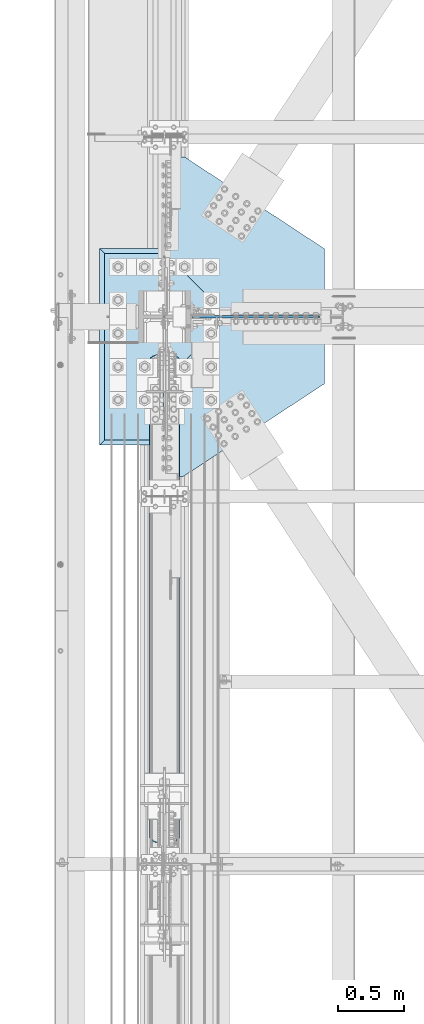
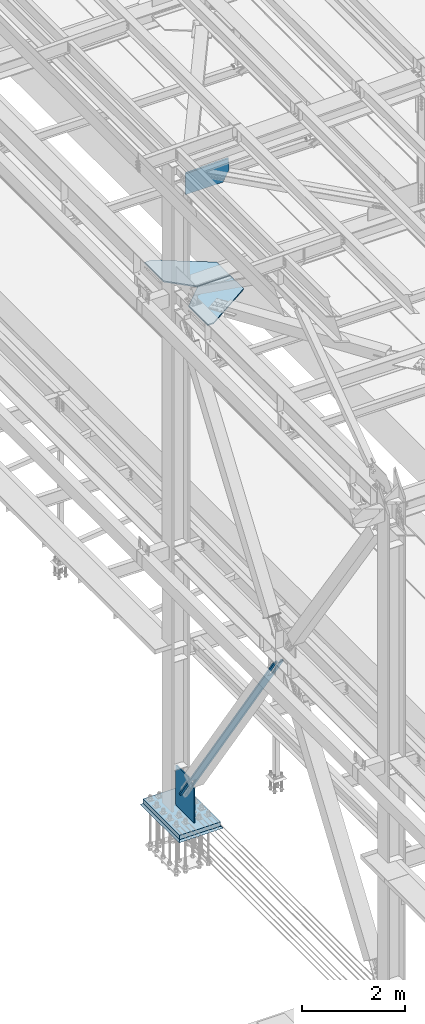
# One storey, part 2978 of 3843: 7 plates, 6 elements without a shape of their own.
"""IFC2X3 building model written with IfcOpenShell, lengths in millimetres."""

from ifc_helpers import new_model, si_unit, frame, origin_with_axes, place, context, subcontext, project, spatial, faceted_brep, material, type_object, element, aggregate, save


model = new_model("IFC2X3")

# Units and contexts
model_context = context("Model", 3, precision=1e-05, world=origin_with_axes())
body_context = subcontext(model_context, "Body", "Model", "MODEL_VIEW")
ifc_project = project(units=[si_unit("LENGTHUNIT", "METRE", prefix="MILLI"), si_unit("AREAUNIT", "SQUARE_METRE"), si_unit("VOLUMEUNIT", "CUBIC_METRE"), si_unit("MASSUNIT", "GRAM", prefix="KILO"), si_unit("TIMEUNIT", "SECOND"), si_unit("PLANEANGLEUNIT", "RADIAN"), si_unit("SOLIDANGLEUNIT", "STERADIAN"), si_unit("THERMODYNAMICTEMPERATUREUNIT", "DEGREE_CELSIUS"), si_unit("LUMINOUSINTENSITYUNIT", "LUMEN")], contexts=[model_context])

# Site, building, storey
site_placement = place(None, origin_with_axes())
site = spatial("IfcSite", under=ifc_project, at=site_placement, CompositionType="ELEMENT")
building_placement = place(site_placement, origin_with_axes())
building = spatial("IfcBuilding", under=site, at=building_placement, Name="Undefined", CompositionType="ELEMENT")
storey_placement = place(building_placement, origin_with_axes())
storey = spatial("IfcBuildingStorey", under=building, at=storey_placement, Name="Undefined", CompositionType="ELEMENT", Elevation=0.0)

# Assembly, plate
assembly_1_placement = place(storey_placement, origin_with_axes())
assembly_1 = element("IfcElementAssembly", 1, at=assembly_1_placement, inside=storey, Name="PLATE", AssemblyPlace="NOTDEFINED", PredefinedType="RIGID_FRAME")
ifc_material_1 = material(Name="STEEL/A572-50")
plate_type_1 = type_object("IfcPlateType", PredefinedType="NOTDEFINED")
plate_1_placement = place(assembly_1_placement, frame((36583.1437500017, 58432.7, 42232.2630004885), z_axis=(1.0, 0.0, 0.0), x_axis=(0.0, -1.0, 0.0)))
plate_1 = element("IfcPlate", 2, at=plate_1_placement, type_object=plate_type_1, material=ifc_material_1, Name="PLATE", context=body_context, shape_type="Brep", body=[
    faceted_brep([(0.0, -14.2874999999985, 0.0), (-475.456249998751, -14.2874999999985, 475.456249999283), (-475.456249998751, 14.2874999999985, 475.456249999283), (0.0, 14.2874999999985, 0.0), (-475.456249998751, -14.2874999999985, 1212.05624999934), (-475.456249998751, 14.2874999999985, 1212.05624999934), (28.9127655419579, -14.2874999999985, 1212.05624999934), (28.9127655419579, 14.2874999999985, 1212.05624999934), (736.600000000006, -14.2874999999985, 134.143749999275), (736.600000000006, 14.2874999999985, 134.143749999275), (736.599999940488, -14.2874999999985, 0.0), (736.599999940488, 14.2874999999985, 0.0)], [[[0, 1, 2, 3]], [[1, 4, 5, 2]], [[4, 6, 7, 5]], [[6, 8, 9, 7]], [[8, 10, 11, 9]], [[10, 0, 3, 11]], [[5, 7, 9, 11, 3, 2]], [[10, 8, 6, 4, 1, 0]]]),
])
aggregate(assembly_1, [plate_1])

assembly_2_placement = place(storey_placement, origin_with_axes())
assembly_2 = element("IfcElementAssembly", 3, at=assembly_2_placement, inside=storey, Name="PLATE", AssemblyPlace="NOTDEFINED", PredefinedType="RIGID_FRAME")
plate_2_placement = place(assembly_2_placement, frame((37058.6, 58922.4437500015, 42232.2630004888), z_axis=(0.0, 1.0, 0.0), x_axis=(1.0, 0.0, 0.0)))
plate_2 = element("IfcPlate", 4, at=plate_2_placement, type_object=plate_type_1, material=ifc_material_1, Name="PLATE", context=body_context, shape_type="Brep", body=[
    faceted_brep([(0.0, -14.2874999999985, 0.0), (-476.249999993554, -14.2874999999985, 475.456250073548), (-476.249999993554, 14.2874999999985, 475.456250073548), (0.0, 14.2874999999985, 0.0), (-476.249999993568, -14.2874999999985, 1212.05625003844), (-476.249999993568, 14.2874999999985, 1212.05625003844), (-327.025000000001, -14.2874999999985, 1212.05624999852), (-327.025000000001, 14.2874999999985, 1212.05624999852), (736.599999997103, -14.2874999999985, 513.749258709016), (736.599999997103, 14.2874999999985, 513.749258709016), (736.599999940488, -14.2874999999985, 0.0), (736.599999940488, 14.2874999999985, 0.0)], [[[0, 1, 2, 3]], [[1, 4, 5, 2]], [[4, 6, 7, 5]], [[6, 8, 9, 7]], [[8, 10, 11, 9]], [[10, 0, 3, 11]], [[5, 7, 9, 11, 3, 2]], [[10, 8, 6, 4, 1, 0]]]),
])
aggregate(assembly_2, [plate_2])

assembly_3_placement = place(storey_placement, origin_with_axes())
assembly_3 = element("IfcElementAssembly", 5, at=assembly_3_placement, inside=storey, Name="BEAM", AssemblyPlace="NOTDEFINED", PredefinedType="RIGID_FRAME")
plate_type_2 = type_object("IfcPlateType", PredefinedType="NOTDEFINED")
plate_3_placement = place(assembly_3_placement, frame((36788.7249999795, 58915.3, 45030.0717313356), z_axis=(1.0, 0.0, 0.0), x_axis=(0.0, 0.0, -1.0)))
plate_3 = element("IfcPlate", 6, at=plate_3_placement, type_object=plate_type_2, material=ifc_material_1, Name="PLATE", context=body_context, shape_type="Brep", body=[
    faceted_brep([(-4.08604394921713, -9.52500000000146, 962.266908610043), (-23.1289214823482, 9.52500000000146, 961.746057199307), (3.17628316901391, 9.52500000000146, 0.0), (22.2334067734992, -9.52500000000146, 0.0), (270.121220165929, -9.52500000000146, 969.766890695173), (270.121220165929, 9.52500000000146, 969.766890695173), (516.322274450198, -9.52500000000146, 837.670706379751), (516.322274450198, 9.52500000000146, 837.670706379751), (516.322274450198, -9.52500000000146, 0.0), (516.322274450198, 9.52500000000146, 0.0)], [[[0, 1, 2, 3]], [[4, 5, 1, 0]], [[4, 6, 7, 5]], [[6, 8, 9, 7]], [[9, 8, 3, 2]], [[5, 7, 9, 2, 1]], [[8, 6, 4, 0, 3]]]),
])
aggregate(assembly_3, [plate_3])

assembly_4_placement = place(storey_placement, origin_with_axes())
assembly_4 = element("IfcElementAssembly", 7, at=assembly_4_placement, inside=storey, Name="COLUMN", AssemblyPlace="NOTDEFINED", PredefinedType="RIGID_FRAME")
plate_type_3 = type_object("IfcPlateType", PredefinedType="NOTDEFINED")
plate_4_placement = place(assembly_4_placement, frame((36576.0, 58902.6, 30162.5), z_axis=(0.0, 0.0, 1.0), x_axis=(0.0, -1.0, 0.0)))
plate_4 = element("IfcPlate", 8, at=plate_4_placement, type_object=plate_type_3, material=ifc_material_1, Name="CB", context=body_context, shape_type="Brep", body=[
    faceted_brep([(0.0, -12.6999999999971, 19.0499992370605), (0.0, -12.6999999999971, 942.254570209607), (0.0, 12.6999999999971, 942.254570209607), (0.0, 12.6999999999971, 19.0499992370605), (19.0499992370605, -12.6999999999971, 961.304569446667), (19.0499992370605, 12.6999999999971, 961.304569446667), (477.459274804351, -12.6999999999971, 961.304569446667), (477.459274804351, 12.6999999999971, 961.304569446667), (707.843688003049, -12.6999999999971, 803.230592603264), (707.843688003049, 12.6999999999971, 803.230592603264), (707.843688003049, -12.6999999999971, 0.0), (707.843688003049, 12.6999999999971, 0.0), (19.0500015258731, -12.6999999999971, -6.33008312433958e-10), (19.0500015258731, 12.6999999999971, 0.0)], [[[0, 1, 2, 3]], [[1, 4, 5, 2]], [[4, 6, 7, 5]], [[6, 8, 9, 7]], [[8, 10, 11, 9]], [[10, 12, 13, 11]], [[12, 0, 3, 13]], [[5, 7, 9, 11, 13, 3, 2]], [[12, 10, 8, 6, 4, 1, 0]]]),
])

assembly_5_placement = place(storey_placement, origin_with_axes())
assembly_5 = element("IfcElementAssembly", 9, at=assembly_5_placement, inside=storey, Name="CB", AssemblyPlace="NOTDEFINED", PredefinedType="RIGID_FRAME")
ifc_material_2 = material(Name="STEEL/A36")
plate_type_4 = type_object("IfcPlateType", PredefinedType="NOTDEFINED")
plate_5_placement = place(assembly_5_placement, frame((36461.7, 58613.1047327072, 30602.9335232757), z_axis=(0.0, -0.565762265008601, 0.824568408012542), x_axis=(1.0, 0.0, 0.0)))
plate_5 = element("IfcPlate", 10, at=plate_5_placement, type_object=plate_type_4, material=ifc_material_2, Name="CB", context=body_context, shape_type="Brep", body=[
    faceted_brep([(0.0, -15.8749999996799, 73.0250015258098), (0.0, -15.8749999668507, 6465.9984944254), (0.0, 15.8750000332511, 6465.99849442527), (0.0, 15.875000000422, 73.0250015256788), (5.55869725451339, -15.8749999667052, 6493.94395265774), (5.55869725451339, 15.8750000333966, 6493.94395265761), (21.3885277507725, -15.8749999665888, 6517.63496820041), (21.3885277507725, 15.8750000335131, 6517.63496820028), (45.0795432934901, -15.874999966516, 6533.46479869664), (45.0795432934901, 15.8750000335858, 6533.46479869651), (73.0250000000015, -15.8749999664869, 6539.02349595114), (73.0250000000015, 15.8750000336149, 6539.02349595101), (73.0250000000015, -15.8750000049622, 5844.43674799455), (73.0250000000015, 15.8749999949505, 5844.43674799455), (155.575000000004, -15.8750000049622, 5844.43674799455), (155.575000000004, 15.8749999949505, 5844.43674799455), (155.574998474127, -15.8749999664869, 6539.02349595114), (155.574998474127, 15.8750000336149, 6539.02349595101), (183.520456706516, -15.874999966516, 6533.46479869664), (183.520456706516, 15.8750000335858, 6533.46479869651), (207.211472249233, -15.8749999665888, 6517.63496820041), (207.211472249233, 15.8750000335131, 6517.63496820028), (223.041302745492, -15.8749999667052, 6493.94395265774), (223.041302745492, 15.8750000333966, 6493.94395265761), (228.600000000006, -15.8749999668507, 6465.9984944254), (228.600000000006, 15.8750000332511, 6465.99849442527), (228.600000000006, -15.8749999996799, 73.0250015258098), (228.600000000006, 15.875000000422, 73.0250015256788), (223.041302745492, -15.8749999998254, 45.0795432934756), (223.041302745492, 15.8750000002765, 45.0795432933373), (207.211472249233, -15.8749999999563, 21.3885277508089), (207.211472249233, 15.8750000001455, 21.3885277506743), (183.520456706516, -15.8750000000291, 5.55869725457887), (183.520456706516, 15.8750000000728, 5.55869725444427), (155.575000000004, -15.8750000000437, 6.54836185276508e-11), (155.574999999975, 15.875, 0.0), (155.575000000004, -15.8750000005384, 694.586748007643), (155.575000000004, 15.8749999993743, 694.586748007639), (73.0250000000015, -15.8750000005384, 694.586748007643), (73.0250000000015, 15.8749999993743, 694.586748007639), (73.0250015258789, -15.8750000000437, 6.54836185276508e-11), (73.0250015258789, 15.8750000000437, -6.18456397205591e-11), (45.0795432934901, -15.8750000000291, 5.55869725457887), (45.0795432934901, 15.8750000000728, 5.55869725444427), (21.3885277507725, -15.8749999999563, 21.3885277508089), (21.3885277507725, 15.8750000001455, 21.3885277506743), (5.55869725451339, -15.8749999998254, 45.0795432934756), (5.55869725451339, 15.8750000002765, 45.0795432933373)], [[[0, 1, 2, 3]], [[1, 4, 5, 2]], [[4, 6, 7, 5]], [[6, 8, 9, 7]], [[8, 10, 11, 9]], [[10, 12, 13, 11]], [[12, 14, 15, 13]], [[14, 16, 17, 15]], [[16, 18, 19, 17]], [[18, 20, 21, 19]], [[20, 22, 23, 21]], [[22, 24, 25, 23]], [[24, 26, 27, 25]], [[26, 28, 29, 27]], [[28, 30, 31, 29]], [[30, 32, 33, 31]], [[32, 34, 35, 33]], [[34, 36, 37, 35]], [[36, 38, 39, 37]], [[38, 40, 41, 39]], [[40, 42, 43, 41]], [[42, 44, 45, 43]], [[44, 46, 47, 45]], [[46, 0, 3, 47]], [[5, 7, 9, 11, 13, 15, 17, 19, 21, 23, 25, 27, 29, 31, 33, 35, 37, 39, 41, 43, 45, 47, 3, 2]], [[46, 44, 42, 40, 38, 36, 34, 32, 30, 28, 26, 24, 22, 20, 18, 16, 14, 12, 10, 8, 6, 4, 1, 0]]]),
])
aggregate(assembly_5, [plate_5])

assembly_6_placement = place(storey_placement, origin_with_axes())
assembly_6 = element("IfcElementAssembly", 11, at=assembly_6_placement, inside=storey, Name="GROUT", AssemblyPlace="NOTDEFINED", PredefinedType="REINFORCEMENT_UNIT")
ifc_material_3 = material(Name="CONCRETE/Concrete_Undefined")
plate_type_5 = type_object("IfcPlateType", PredefinedType="NOTDEFINED")
plate_6_placement = place(assembly_6_placement, frame((36080.7, 57937.4, 30041.85), z_axis=(0.0, 1.0, 0.0), x_axis=(1.0, 0.0, 0.0)))
plate_6 = element("IfcPlate", 12, at=plate_6_placement, type_object=plate_type_5, material=ifc_material_3, Name="GROUT", context=body_context, shape_type="Brep", body=[
    faceted_brep([(38.0999999997948, -19.0499999997955, 1460.49999999932), (0.0, 19.0499999999993, 1498.59997558594), (0.0, 19.0500000000029, 0.0), (38.1000000006916, -19.0499999999811, 38.1000000006607), (952.500000000204, -19.0499999998101, 38.1000000006607), (990.599975585938, 19.0499999999993, 0.0), (990.599975585938, 19.0499999999993, 1498.59997558594), (952.500000000204, -19.0499999999956, 1460.49999999932)], [[[0, 1, 2, 3]], [[4, 5, 6, 7]], [[4, 7, 0, 3]], [[5, 4, 3, 2]], [[6, 5, 2, 1]], [[7, 6, 1, 0]]]),
])
aggregate(assembly_6, [plate_6])

# Plate
plate_type_6 = type_object("IfcPlateType", PredefinedType="NOTDEFINED")
plate_7_placement = place(assembly_4_placement, frame((36118.8, 57975.5, 30111.7), z_axis=(0.0, 1.0, 0.0), x_axis=(1.0, 0.0, 0.0)))
plate_7 = element("IfcPlate", 13, at=plate_7_placement, type_object=plate_type_6, material=ifc_material_1, Name="PLATE", context=body_context, shape_type="Brep", body=[
    faceted_brep([(0.0, -50.7999999999993, 0.0), (0.0, -50.7999999999993, 1422.40002441406), (0.0, 50.7999999999993, 1422.40002441406), (0.0, 50.7999999999993, 0.0), (914.400024414062, -50.7999999999993, 1422.40002441406), (914.400024414062, 50.7999999999993, 1422.40002441406), (914.400024414062, -50.7999999999993, 0.0), (914.400024414062, 50.7999999999993, 0.0)], [[[0, 1, 2, 3]], [[1, 4, 5, 2]], [[4, 6, 7, 5]], [[6, 0, 3, 7]], [[5, 7, 3, 2]], [[6, 4, 1, 0]]]),
])

aggregate(assembly_4, [plate_4, plate_7])

save(model, "model.ifc")
